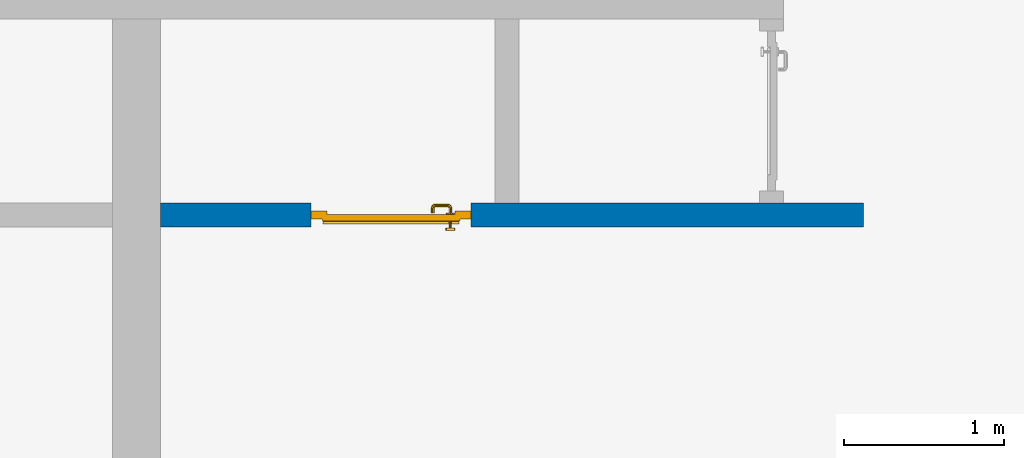
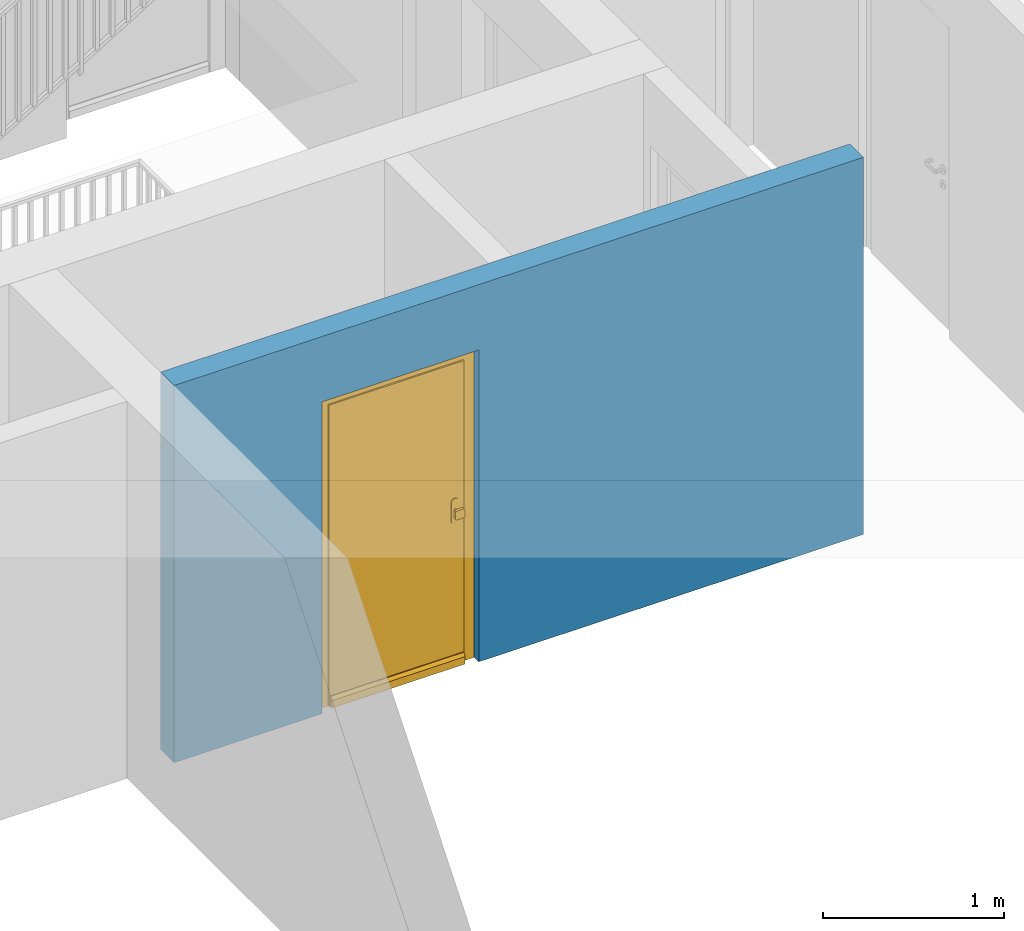
# One storey, part 3 of 54: 1 door, 1 wall, 1 opening.
"""IFC4 building model written with IfcOpenShell, lengths in metres."""

from ifc_helpers import new_model, entity, si_unit, converted_unit, derived_unit, direction, frame, origin_with_axes, place, context, subcontext, project, spatial, polygons, source, transform, mapped, material, type_object, element, fill, save


model = new_model("IFC4")

# Units and contexts
model_context = context("Model", 3, precision=1e-05, world=origin_with_axes(), true_north=direction((0.0, 1.0)))
body_context = subcontext(model_context, "Body", "Model", "MODEL_VIEW")
ifc_project = project(units=[si_unit("LENGTHUNIT", "METRE"), si_unit("AREAUNIT", "SQUARE_METRE"), si_unit("VOLUMEUNIT", "CUBIC_METRE"), converted_unit("PLANEANGLEUNIT", "DEGREE", entity("IfcPlaneAngleMeasure", 0.0174532925199), si_unit("PLANEANGLEUNIT", "RADIAN"), dimensions=[0, 0, 0, 0, 0, 0, 0]), converted_unit("TIMEUNIT", "Year", entity("IfcTimeMeasure", 31556926.0), si_unit("TIMEUNIT", "SECOND"), dimensions=[0, 0, 1, 0, 0, 0, 0]), si_unit("MASSUNIT", "GRAM", prefix="KILO"), si_unit("THERMODYNAMICTEMPERATUREUNIT", "DEGREE_CELSIUS"), si_unit("LUMINOUSINTENSITYUNIT", "LUMEN"), si_unit("ENERGYUNIT", "JOULE", prefix="MEGA"), derived_unit("THERMALCONDUCTANCEUNIT", [(si_unit("POWERUNIT", "WATT"), 1), (si_unit("LENGTHUNIT", "METRE"), -1), (si_unit("THERMODYNAMICTEMPERATUREUNIT", "KELVIN"), -1)]), derived_unit("SPECIFICHEATCAPACITYUNIT", [(si_unit("ENERGYUNIT", "JOULE"), 1), (si_unit("MASSUNIT", "GRAM", prefix="KILO"), -1), (si_unit("THERMODYNAMICTEMPERATUREUNIT", "KELVIN"), -1)]), derived_unit("MASSDENSITYUNIT", [(si_unit("MASSUNIT", "GRAM", prefix="KILO"), 1), (si_unit("VOLUMEUNIT", "CUBIC_METRE"), -1)])], contexts=[model_context])

# Site, building, storey
site_placement = place(None, origin_with_axes())
site = spatial("IfcSite", under=ifc_project, at=site_placement, CompositionType="ELEMENT")
building_placement = place(site_placement, origin_with_axes())
building = spatial("IfcBuilding", under=site, at=building_placement, CompositionType="ELEMENT")
storey_placement = place(building_placement, frame((0.0, 0.0, 6.29), z_axis=(0.0, 0.0, 1.0), x_axis=(1.0, 0.0, 0.0)))
storey = spatial("IfcBuildingStorey", under=building, at=storey_placement, Name="2. Geschoss", CompositionType="ELEMENT", Elevation=6.29)

# Wall, opening, door
ifc_material = material()
wall_type = type_object("IfcWallType", Name="150", PredefinedType="NOTDEFINED")
wall_placement = place(storey_placement, frame((-1.2021993804, -4.12881223104, 0.0), z_axis=(0.0, 0.0, 1.0), x_axis=(1.0, 0.0, 0.0)))
wall = element("IfcWall", 1, at=wall_placement, inside=storey, type_object=wall_type, material=ifc_material, Name="Wand-002", PredefinedType="NOTDEFINED", context=body_context, shape_type="Tessellation", body=[
    polygons([(1.09, 0.15, 2.1), (1.09, 0.15, 0.0), (0.15, 0.15, 0.0), (0.15, 0.15, 2.54), (4.54, 0.15, 2.54), (4.54, 0.15, 0.0), (2.09, 0.15, 0.0), (2.09, 0.15, 2.1), (1.09, 0.05, 0.0), (1.09, 0.0, 2.1), (1.09, 0.0, 0.0), (0.15, 0.0, 0.0), (0.15, 0.0, 2.54), (4.54, 0.0, 2.54), (4.54, 0.0, 0.0), (2.09, 0.05, 0.0), (2.09, 0.0, 0.0), (2.09, 0.0, 2.1)], [[[1, 2, 3, 4, 5, 6, 7, 8]], [[9, 2, 1, 10, 11]], [[2, 9, 11, 12, 3]], [[4, 3, 12, 13]], [[5, 4, 13, 14]], [[14, 15, 6, 5]], [[16, 7, 6, 15, 17]], [[8, 7, 16, 17, 18]], [[1, 8, 18, 10]], [[12, 11, 10, 18, 17, 15, 14, 13]]], closed=True),
])
opening_placement = place(wall_placement, frame((1.59, 0.0, 0.0), z_axis=(0.0, 0.0, 1.0), x_axis=(1.0, 0.0, 0.0)))
opening = element("IfcOpeningElement", 2, at=opening_placement, cuts=wall, context=body_context, identifier="Reference", shape_type="Tessellation", body=[
    polygons([(0.5, 0.05, 0.0), (0.5, 0.05, 2.1), (0.5, -0.001, 2.1), (0.5, -0.001, 0.0), (0.5, 0.151, 0.0), (0.5, 0.151, 2.1), (-0.5, 0.05, 2.1), (-0.5, -0.001, 2.1), (-0.5, 0.151, 2.1), (-0.5, -0.001, 0.0), (-0.5, 0.05, 0.0), (-0.5, 0.151, 0.0)], [[[1, 2, 3, 4]], [[2, 1, 5, 6]], [[7, 8, 3, 2, 6, 9]], [[8, 10, 4, 3]], [[1, 4, 10, 11, 12, 5]], [[6, 5, 12, 9]], [[7, 11, 10, 8]], [[11, 7, 9, 12]]], closed=True),
])
door_type = type_object("IfcDoorType", Name="Eingang 01 1-Fl 26", OperationType="SINGLE_SWING_RIGHT", PredefinedType="DOOR")
shared_shape = source(origin_with_axes(), body_context, "Body", "Tessellation", [
    polygons([(0.5, -0.05, 0.0), (0.5, -0.03, 0.0), (0.5, -0.03, 2.1), (0.5, -0.05, 2.1), (0.4, -0.05, 0.0), (0.4, -0.03, 0.0), (0.4, -0.03, 2.0), (0.1301, -0.03, 2.0), (0.0001, -0.03, 2.0), (-0.4, -0.03, 2.0), (-0.4, -0.03, 0.0), (-0.5, -0.03, 0.0), (-0.5, -0.03, 2.1), (-0.5, -0.05, 2.1), (-0.5, -0.05, 0.0), (-0.4, -0.05, 0.0), (-0.4, -0.05, 2.0), (0.0001, -0.05, 2.0), (0.1301, -0.05, 2.0), (0.4, -0.05, 2.0)], [[[1, 2, 3, 4]], [[5, 6, 2, 1]], [[2, 6, 7, 8, 9, 10, 11, 12, 13, 3]], [[4, 3, 13, 14]], [[1, 4, 14, 15, 16, 17, 18, 19, 20, 5]], [[20, 7, 6, 5]], [[19, 8, 7, 20]], [[18, 9, 8, 19]], [[17, 10, 9, 18]], [[16, 11, 10, 17]], [[15, 12, 11, 16]], [[14, 13, 12, 15]]], closed=True),
    polygons([(0.5, -0.03, 0.0), (0.5, 0.0, 0.0), (0.5, 0.0, 2.1), (0.5, -0.03, 2.1), (0.43, -0.03, 0.0), (0.43, 0.0, 0.0), (0.43, 0.0, 2.03), (0.1001, 0.0, 2.03), (0.0301, 0.0, 2.03), (-0.43, 0.0, 2.03), (-0.43, 0.0, 0.0), (-0.5, 0.0, 0.0), (-0.5, 0.0, 2.1), (-0.5, -0.03, 2.1), (-0.5, -0.03, 0.0), (-0.43, -0.03, 0.0), (-0.43, -0.03, 2.03), (0.0301, -0.03, 2.03), (0.1001, -0.03, 2.03), (0.43, -0.03, 2.03)], [[[1, 2, 3, 4]], [[5, 6, 2, 1]], [[2, 6, 7, 8, 9, 10, 11, 12, 13, 3]], [[4, 3, 13, 14]], [[1, 4, 14, 15, 16, 17, 18, 19, 20, 5]], [[20, 7, 6, 5]], [[19, 8, 7, 20]], [[18, 9, 8, 19]], [[17, 10, 9, 18]], [[16, 11, 10, 17]], [[15, 12, 11, 16]], [[14, 13, 12, 15]]], closed=True),
    polygons([(0.43, 0.01, 0.0), (-0.43, 0.01, 0.0), (-0.43, 0.01, 2.03), (0.43, 0.01, 2.03), (0.43, -0.03, 0.0), (-0.43, -0.03, 0.0), (-0.43, -0.03, 2.03), (0.43, -0.03, 2.03)], [[[1, 2, 3, 4]], [[2, 1, 5, 6]], [[3, 2, 6, 7]], [[4, 3, 7, 8]], [[1, 4, 8, 5]], [[6, 5, 8, 7]]], closed=True),
    polygons([(0.425, 0.03, 0.0), (-0.425, 0.03, 0.0), (-0.425, 0.03, 0.05), (0.425, 0.03, 0.05), (0.425, 0.01, 0.0), (-0.425, 0.01, 0.0), (-0.425, 0.01, 0.07), (-0.425, 0.015, 0.07), (0.425, 0.015, 0.07), (0.425, 0.01, 0.07)], [[[1, 2, 3, 4]], [[5, 6, 2, 1]], [[2, 6, 7, 8, 3]], [[4, 3, 8, 9]], [[1, 4, 9, 10, 5]], [[10, 7, 6, 5]], [[9, 8, 7, 10]]], closed=True),
    polygons([(-0.3835, -0.04, 1.0733826859), (-0.37, -0.04, 1.077), (-0.37, -0.0399, 1.077), (-0.3835, -0.0399, 1.0733826859), (-0.393382685902, -0.04, 1.0635), (-0.397, -0.04, 1.05), (-0.393382685902, -0.04, 1.0365), (-0.3835, -0.04, 1.0266173141), (-0.37, -0.04, 1.023), (-0.3565, -0.04, 1.0266173141), (-0.346617314098, -0.04, 1.0365), (-0.343, -0.04, 1.05), (-0.346617314098, -0.04, 1.0635), (-0.3565, -0.04, 1.0733826859), (-0.3565, -0.0399, 1.0733826859), (-0.37, -0.0301, 1.077), (-0.3835, -0.0301, 1.0733826859), (-0.393382685902, -0.0399, 1.0635), (-0.397, -0.0399, 1.05), (-0.393382685902, -0.0399, 1.0365), (-0.3835, -0.0399, 1.0266173141), (-0.37, -0.0399, 1.023), (-0.3565, -0.0399, 1.0266173141), (-0.346617314098, -0.0399, 1.0365), (-0.343, -0.0399, 1.05), (-0.346617314098, -0.0399, 1.0635), (-0.3565, -0.0301, 1.0733826859), (-0.37, -0.03, 1.077), (-0.3835, -0.03, 1.0733826859), (-0.393382685902, -0.0301, 1.0635), (-0.397, -0.0301, 1.05), (-0.393382685902, -0.0301, 1.0365), (-0.3835, -0.0301, 1.0266173141), (-0.37, -0.0301, 1.023), (-0.3565, -0.0301, 1.0266173141), (-0.346617314098, -0.0301, 1.0365), (-0.343, -0.0301, 1.05), (-0.346617314098, -0.0301, 1.0635), (-0.3565, -0.03, 1.0733826859), (-0.346617314098, -0.03, 1.0635), (-0.343, -0.03, 1.05), (-0.346617314098, -0.03, 1.0365), (-0.3565, -0.03, 1.0266173141), (-0.37, -0.03, 1.023), (-0.3835, -0.03, 1.0266173141), (-0.393382685902, -0.03, 1.0365), (-0.397, -0.03, 1.05), (-0.393382685902, -0.03, 1.0635)], [[[1, 2, 3, 4]], [[2, 1, 5, 6, 7, 8, 9, 10, 11, 12, 13, 14]], [[2, 14, 15, 3]], [[4, 3, 16, 17]], [[5, 1, 4, 18]], [[6, 5, 18, 19]], [[7, 6, 19, 20]], [[8, 7, 20, 21]], [[9, 8, 21, 22]], [[10, 9, 22, 23]], [[11, 10, 23, 24]], [[12, 11, 24, 25]], [[13, 12, 25, 26]], [[14, 13, 26, 15]], [[3, 15, 27, 16]], [[17, 16, 28, 29]], [[18, 4, 17, 30]], [[19, 18, 30, 31]], [[20, 19, 31, 32]], [[21, 20, 32, 33]], [[22, 21, 33, 34]], [[23, 22, 34, 35]], [[24, 23, 35, 36]], [[25, 24, 36, 37]], [[26, 25, 37, 38]], [[15, 26, 38, 27]], [[16, 27, 39, 28]], [[28, 39, 40, 41, 42, 43, 44, 45, 46, 47, 48, 29]], [[30, 17, 29, 48]], [[31, 30, 48, 47]], [[32, 31, 47, 46]], [[33, 32, 46, 45]], [[34, 33, 45, 44]], [[35, 34, 44, 43]], [[36, 35, 43, 42]], [[37, 36, 42, 41]], [[38, 37, 41, 40]], [[27, 38, 40, 39]]], closed=True),
    polygons([(-0.362532169224, -0.04, 0.959692280177), (-0.365, -0.04, 0.9544), (-0.365, -0.04, 0.952886751346), (-0.346703916638, -0.04, 0.96345), (-0.35655, -0.04, 0.973296083362), (-0.363279754556, -0.04, 0.961639806549), (-0.362532169224, -0.039, 0.959692280177), (-0.365, -0.039, 0.9544), (-0.365, -0.039, 0.952886751346), (-0.365, -0.039, 0.95), (-0.365, -0.039, 0.947113248654), (-0.365, -0.039, 0.941339745962), (-0.365, -0.039, 0.9375), (-0.365, -0.04, 0.9375), (-0.365, -0.04, 0.941339745962), (-0.365, -0.04, 0.947113248654), (-0.365, -0.04, 0.95), (-0.3431, -0.04, 0.95), (-0.346617314098, -0.04, 0.9635), (-0.3565, -0.04, 0.973382685902), (-0.364624817685, -0.04, 0.965143815798), (-0.37, -0.04, 0.9769), (-0.37, -0.04, 0.967425445323), (-0.364624817685, -0.039, 0.965143815798), (-0.363279754556, -0.039, 0.961639806549), (-0.35705, -0.039, 0.972430057958), (-0.347569942042, -0.039, 0.96295), (-0.3441, -0.039, 0.95), (-0.347569942042, -0.039, 0.93705), (-0.35705, -0.039, 0.927569942042), (-0.37, -0.039, 0.9241), (-0.37, -0.039, 0.9325), (-0.366464466094, -0.039, 0.933964466094), (-0.366464466094, -0.04, 0.933964466094), (-0.35655, -0.04, 0.926703916638), (-0.37, -0.04, 0.9325), (-0.37, -0.04, 0.9231), (-0.346703916638, -0.04, 0.93655), (-0.343, -0.04, 0.95), (-0.346617314098, -0.0399, 0.9635), (-0.3565, -0.0399, 0.973382685902), (-0.37, -0.04, 0.977), (-0.375375182315, -0.04, 0.965143815798), (-0.38345, -0.04, 0.973296083362), (-0.376720245444, -0.04, 0.961639806549), (-0.37, -0.039, 0.967425445323), (-0.37, -0.039, 0.9759), (-0.357, -0.039, 0.972516660498), (-0.347483339502, -0.039, 0.963), (-0.344, -0.039, 0.95), (-0.347483339502, -0.039, 0.937), (-0.357, -0.039, 0.927483339502), (-0.38295, -0.039, 0.927569942042), (-0.375, -0.039, 0.941339745962), (-0.375, -0.039, 0.9375), (-0.373535533906, -0.039, 0.933964466094), (-0.37, -0.039, 0.924), (-0.373535533906, -0.04, 0.933964466094), (-0.375, -0.04, 0.9375), (-0.375, -0.04, 0.941339745962), (-0.38345, -0.04, 0.926703916638), (-0.37, -0.04, 0.923), (-0.3565, -0.04, 0.926617314098), (-0.346617314098, -0.04, 0.9365), (-0.343, -0.0399, 0.95), (-0.346617314098, -0.0301, 0.9635), (-0.3565, -0.0301, 0.973382685902), (-0.37, -0.0399, 0.977), (-0.3835, -0.04, 0.973382685902), (-0.375375182315, -0.039, 0.965143815798), (-0.377467830776, -0.04, 0.959692280177), (-0.393296083362, -0.04, 0.96345), (-0.375, -0.04, 0.952886751346), (-0.375, -0.04, 0.9544), (-0.377467830776, -0.039, 0.959692280177), (-0.376720245444, -0.039, 0.961639806549), (-0.38295, -0.039, 0.972430057958), (-0.37, -0.039, 0.976), (-0.357, -0.0389, 0.972516660498), (-0.347483339502, -0.0389, 0.963), (-0.344, -0.0389, 0.95), (-0.347483339502, -0.0389, 0.937), (-0.357, -0.0389, 0.927483339502), (-0.392430057958, -0.039, 0.93705), (-0.375, -0.039, 0.947113248654), (-0.375, -0.039, 0.9544), (-0.375, -0.04, 0.95), (-0.375, -0.04, 0.947113248654), (-0.375, -0.039, 0.95), (-0.375, -0.039, 0.952886751346), (-0.383, -0.039, 0.927483339502), (-0.37, -0.0389, 0.924), (-0.393296083362, -0.04, 0.93655), (-0.3835, -0.04, 0.926617314098), (-0.37, -0.0399, 0.923), (-0.3565, -0.0399, 0.926617314098), (-0.346617314098, -0.0399, 0.9365), (-0.343, -0.0301, 0.95), (-0.346617314098, -0.03, 0.9635), (-0.3565, -0.03, 0.973382685902), (-0.37, -0.0301, 0.977), (-0.3835, -0.0399, 0.973382685902), (-0.393382685902, -0.04, 0.9635), (-0.3969, -0.04, 0.95), (-0.392430057958, -0.039, 0.96295), (-0.383, -0.039, 0.972516660498), (-0.37, -0.0389, 0.976), (-0.357, -0.0301, 0.972516660498), (-0.347483339502, -0.0301, 0.963), (-0.344, -0.0301, 0.95), (-0.347483339502, -0.0301, 0.937), (-0.357, -0.0301, 0.927483339502), (-0.392516660498, -0.039, 0.937), (-0.3959, -0.039, 0.95), (-0.383, -0.0389, 0.927483339502), (-0.37, -0.0301, 0.924), (-0.393382685902, -0.04, 0.9365), (-0.3835, -0.0399, 0.926617314098), (-0.37, -0.0301, 0.923), (-0.3565, -0.0301, 0.926617314098), (-0.346617314098, -0.0301, 0.9365), (-0.343, -0.03, 0.95), (-0.346703916638, -0.03, 0.96345), (-0.35655, -0.03, 0.973296083362), (-0.37, -0.03, 0.977), (-0.3835, -0.0301, 0.973382685902), (-0.393382685902, -0.0399, 0.9635), (-0.397, -0.04, 0.95), (-0.392516660498, -0.039, 0.963), (-0.383, -0.0389, 0.972516660498), (-0.37, -0.0301, 0.976), (-0.357, -0.03, 0.972516660498), (-0.347483339502, -0.03, 0.963), (-0.344, -0.03, 0.95), (-0.347483339502, -0.03, 0.937), (-0.357, -0.03, 0.927483339502), (-0.392516660498, -0.0389, 0.937), (-0.396, -0.039, 0.95), (-0.383, -0.0301, 0.927483339502), (-0.37, -0.03, 0.924), (-0.393382685902, -0.0399, 0.9365), (-0.3835, -0.0301, 0.926617314098), (-0.37, -0.03, 0.923), (-0.3565, -0.03, 0.926617314098), (-0.346617314098, -0.03, 0.9365), (-0.3431, -0.03, 0.95), (-0.347396736961, -0.03, 0.96305), (-0.35695, -0.03, 0.972603263039), (-0.37, -0.03, 0.9769), (-0.3835, -0.03, 0.973382685902), (-0.393382685902, -0.0301, 0.9635), (-0.397, -0.0399, 0.95), (-0.392516660498, -0.0389, 0.963), (-0.383, -0.0301, 0.972516660498), (-0.37, -0.03, 0.976), (-0.3439, -0.03, 0.95), (-0.347396736961, -0.03, 0.93695), (-0.35695, -0.03, 0.927396736961), (-0.392516660498, -0.0301, 0.937), (-0.396, -0.0389, 0.95), (-0.383, -0.03, 0.927483339502), (-0.37, -0.03, 0.9239), (-0.393382685902, -0.0301, 0.9365), (-0.3835, -0.03, 0.926617314098), (-0.37, -0.03, 0.9231), (-0.35655, -0.03, 0.926703916638), (-0.346703916638, -0.03, 0.93655), (-0.37, -0.03, 0.9761), (-0.38345, -0.03, 0.973296083362), (-0.393382685902, -0.03, 0.9635), (-0.397, -0.0301, 0.95), (-0.392516660498, -0.0301, 0.963), (-0.383, -0.03, 0.972516660498), (-0.392516660498, -0.03, 0.937), (-0.396, -0.0301, 0.95), (-0.38305, -0.03, 0.927396736961), (-0.393382685902, -0.03, 0.9365), (-0.38345, -0.03, 0.926703916638), (-0.38305, -0.03, 0.972603263039), (-0.393296083362, -0.03, 0.96345), (-0.397, -0.03, 0.95), (-0.392516660498, -0.03, 0.963), (-0.392603263039, -0.03, 0.93695), (-0.396, -0.03, 0.95), (-0.393296083362, -0.03, 0.93655), (-0.392603263039, -0.03, 0.96305), (-0.3969, -0.03, 0.95), (-0.3961, -0.03, 0.95)], [[[1, 2, 3, 4, 5, 6]], [[2, 1, 7, 8]], [[2, 8, 9, 10, 11, 12, 13, 14, 15, 16, 17, 3]], [[17, 18, 4, 3]], [[19, 20, 5, 4]], [[21, 6, 5, 22, 23]], [[1, 6, 21, 24, 25, 7]], [[7, 25, 26, 27, 9, 8]], [[9, 27, 28, 10]], [[10, 28, 29, 11]], [[11, 29, 30, 12]], [[31, 32, 33, 13, 12, 30]], [[14, 13, 33, 34]], [[35, 15, 14, 34, 36, 37]], [[15, 35, 38, 16]], [[16, 38, 18, 17]], [[39, 19, 4, 18]], [[40, 41, 20, 19]], [[20, 42, 22, 5]], [[43, 23, 22, 44, 45]], [[21, 23, 46, 24]], [[24, 46, 47, 26, 25]], [[27, 26, 48, 49]], [[28, 27, 49, 50]], [[29, 28, 50, 51]], [[30, 29, 51, 52]], [[53, 54, 55, 56, 32, 31]], [[34, 33, 32, 36]], [[31, 30, 52, 57]], [[37, 36, 58, 59, 60, 61]], [[62, 63, 35, 37]], [[63, 64, 38, 35]], [[64, 39, 18, 38]], [[65, 40, 19, 39]], [[66, 67, 41, 40]], [[41, 68, 42, 20]], [[42, 69, 44, 22]], [[23, 43, 70, 46]], [[71, 45, 44, 72, 73, 74]], [[43, 45, 71, 75, 76, 70]], [[70, 76, 77, 47, 46]], [[26, 47, 78, 48]], [[49, 48, 79, 80]], [[50, 49, 80, 81]], [[51, 50, 81, 82]], [[52, 51, 82, 83]], [[54, 53, 84, 85]], [[86, 74, 73, 87, 88, 60, 59, 55, 54, 85, 89, 90]], [[58, 56, 55, 59]], [[36, 32, 56, 58]], [[53, 31, 57, 91]], [[57, 52, 83, 92]], [[88, 93, 61, 60]], [[94, 62, 37, 61]], [[95, 96, 63, 62]], [[96, 97, 64, 63]], [[97, 65, 39, 64]], [[98, 66, 40, 65]], [[99, 100, 67, 66]], [[67, 101, 68, 41]], [[68, 102, 69, 42]], [[69, 103, 72, 44]], [[73, 72, 104, 87]], [[71, 74, 86, 75]], [[75, 86, 90, 105, 77, 76]], [[47, 77, 106, 78]], [[48, 78, 107, 79]], [[80, 79, 108, 109]], [[81, 80, 109, 110]], [[82, 81, 110, 111]], [[83, 82, 111, 112]], [[84, 53, 91, 113]], [[85, 84, 114, 89]], [[87, 104, 93, 88]], [[89, 114, 105, 90]], [[91, 57, 92, 115]], [[92, 83, 112, 116]], [[117, 94, 61, 93]], [[118, 95, 62, 94]], [[119, 120, 96, 95]], [[120, 121, 97, 96]], [[121, 98, 65, 97]], [[122, 99, 66, 98]], [[123, 124, 100, 99]], [[100, 125, 101, 67]], [[101, 126, 102, 68]], [[102, 127, 103, 69]], [[103, 128, 104, 72]], [[77, 105, 129, 106]], [[78, 106, 130, 107]], [[79, 107, 131, 108]], [[109, 108, 132, 133]], [[110, 109, 133, 134]], [[111, 110, 134, 135]], [[112, 111, 135, 136]], [[113, 91, 115, 137]], [[114, 84, 113, 138]], [[128, 117, 93, 104]], [[105, 114, 138, 129]], [[115, 92, 116, 139]], [[116, 112, 136, 140]], [[141, 118, 94, 117]], [[142, 119, 95, 118]], [[143, 144, 120, 119]], [[144, 145, 121, 120]], [[145, 122, 98, 121]], [[146, 123, 99, 122]], [[147, 148, 124, 123]], [[124, 149, 125, 100]], [[125, 150, 126, 101]], [[126, 151, 127, 102]], [[127, 152, 128, 103]], [[106, 129, 153, 130]], [[107, 130, 154, 131]], [[108, 131, 155, 132]], [[133, 132, 148, 147]], [[134, 133, 147, 156]], [[135, 134, 156, 157]], [[136, 135, 157, 158]], [[137, 115, 139, 159]], [[138, 113, 137, 160]], [[152, 141, 117, 128]], [[129, 138, 160, 153]], [[139, 116, 140, 161]], [[140, 136, 158, 162]], [[163, 142, 118, 141]], [[164, 143, 119, 142]], [[165, 166, 144, 143]], [[166, 167, 145, 144]], [[167, 146, 122, 145]], [[156, 147, 123, 146]], [[148, 168, 149, 124]], [[149, 169, 150, 125]], [[150, 170, 151, 126]], [[151, 171, 152, 127]], [[130, 153, 172, 154]], [[131, 154, 173, 155]], [[132, 155, 168, 148]], [[157, 156, 146, 167]], [[158, 157, 167, 166]], [[159, 139, 161, 174]], [[160, 137, 159, 175]], [[171, 163, 141, 152]], [[153, 160, 175, 172]], [[161, 140, 162, 176]], [[162, 158, 166, 165]], [[177, 164, 142, 163]], [[178, 165, 143, 164]], [[168, 179, 169, 149]], [[169, 180, 170, 150]], [[170, 181, 171, 151]], [[154, 172, 182, 173]], [[155, 173, 179, 168]], [[174, 161, 176, 183]], [[175, 159, 174, 184]], [[181, 177, 163, 171]], [[172, 175, 184, 182]], [[176, 162, 165, 178]], [[185, 178, 164, 177]], [[179, 186, 180, 169]], [[180, 187, 181, 170]], [[173, 182, 186, 179]], [[183, 176, 178, 185]], [[184, 174, 183, 188]], [[187, 185, 177, 181]], [[182, 184, 188, 186]], [[186, 188, 187, 180]], [[188, 183, 185, 187]]], closed=True),
    polygons([(-0.38, -0.04, 1.05), (-0.377071067812, -0.04, 1.04292893219), (-0.377071067812, -0.070696439392, 1.04292893219), (-0.38, -0.0709849140336, 1.05), (-0.37, -0.04, 1.04), (-0.37, -0.07, 1.04), (-0.375518993221, -0.0784992452783, 1.04292893219), (-0.378277987014, -0.0796420579258, 1.05), (-0.377071067812, -0.04, 1.05707106781), (-0.377071067812, -0.070696439392, 1.05707106781), (-0.362928932188, -0.04, 1.04292893219), (-0.362928932188, -0.069303560608, 1.04292893219), (-0.368858192988, -0.0757402514855, 1.04), (-0.370704557509, -0.0857045575088, 1.04292893219), (-0.372816199938, -0.0878161999379, 1.05), (-0.375518993221, -0.0784992452783, 1.05707106781), (-0.37, -0.04, 1.06), (-0.37, -0.07, 1.06), (-0.36, -0.04, 1.05), (-0.36, -0.0690150859664, 1.05), (-0.362197392755, -0.0729812576926, 1.04292893219), (-0.365606601718, -0.0806066017178, 1.04), (-0.363499245278, -0.0905189932208, 1.04292893219), (-0.364642057926, -0.0932779870137, 1.05), (-0.370704557509, -0.0857045575088, 1.05707106781), (-0.368858192988, -0.0757402514855, 1.06), (-0.362928932188, -0.04, 1.05707106781), (-0.362928932188, -0.069303560608, 1.05707106781), (-0.359438398962, -0.0718384450452, 1.05), (-0.360508645927, -0.0755086459268, 1.04292893219), (-0.360740251485, -0.0838581929877, 1.04), (-0.355696439392, -0.0920710678119, 1.04292893219), (-0.355984914034, -0.095, 1.05), (-0.363499245278, -0.0905189932208, 1.05707106781), (-0.365606601718, -0.0806066017178, 1.06), (-0.362197392755, -0.0729812576926, 1.05707106781), (-0.358397003498, -0.0733970034977, 1.05), (-0.357981257693, -0.0771973927545, 1.04292893219), (-0.355, -0.085, 1.04), (-0.274303560608, -0.0920710678119, 1.04292893219), (-0.274015085966, -0.095, 1.05), (-0.355696439392, -0.0920710678119, 1.05707106781), (-0.360740251485, -0.0838581929877, 1.06), (-0.360508645927, -0.0755086459268, 1.05707106781), (-0.356838445045, -0.0744383989617, 1.05), (-0.354303560608, -0.0779289321881, 1.04292893219), (-0.275, -0.085, 1.04), (-0.266500754722, -0.0905189932208, 1.04292893219), (-0.265357942074, -0.0932779870137, 1.05), (-0.274303560608, -0.0920710678119, 1.05707106781), (-0.355, -0.085, 1.06), (-0.357981257693, -0.0771973927545, 1.05707106781), (-0.354015085966, -0.075, 1.05), (-0.275696439392, -0.0779289321881, 1.04292893219), (-0.269259748515, -0.0838581929877, 1.04), (-0.259295442491, -0.0857045575088, 1.04292893219), (-0.257183800062, -0.0878161999379, 1.05), (-0.266500754722, -0.0905189932208, 1.05707106781), (-0.275, -0.085, 1.06), (-0.354303560608, -0.0779289321881, 1.05707106781), (-0.275984914034, -0.075, 1.05), (-0.272018742307, -0.0771973927545, 1.04292893219), (-0.264393398282, -0.0806066017178, 1.04), (-0.254481006779, -0.0784992452783, 1.04292893219), (-0.251722012986, -0.0796420579258, 1.05), (-0.259295442491, -0.0857045575088, 1.05707106781), (-0.269259748515, -0.0838581929877, 1.06), (-0.275696439392, -0.0779289321881, 1.05707106781), (-0.273161554955, -0.0744383989617, 1.05), (-0.269491354073, -0.0755086459268, 1.04292893219), (-0.261141807012, -0.0757402514855, 1.04), (-0.252928932188, -0.070696439392, 1.04292893219), (-0.25, -0.0709849140336, 1.05), (-0.254481006779, -0.0784992452783, 1.05707106781), (-0.264393398282, -0.0806066017178, 1.06), (-0.272018742307, -0.0771973927545, 1.05707106781), (-0.271602996502, -0.0733970034977, 1.05), (-0.267802607245, -0.0729812576926, 1.04292893219), (-0.26, -0.07, 1.04), (-0.252928932188, -0.04, 1.04292893219), (-0.25, -0.04, 1.05), (-0.252928932188, -0.070696439392, 1.05707106781), (-0.261141807012, -0.0757402514855, 1.06), (-0.269491354073, -0.0755086459268, 1.05707106781), (-0.270561601038, -0.0718384450452, 1.05), (-0.267071067812, -0.069303560608, 1.04292893219), (-0.26, -0.04, 1.04), (-0.267071067812, -0.04, 1.04292893219), (-0.27, -0.04, 1.05), (-0.267071067812, -0.04, 1.05707106781), (-0.26, -0.04, 1.06), (-0.252928932188, -0.04, 1.05707106781), (-0.26, -0.07, 1.06), (-0.267802607245, -0.0729812576926, 1.05707106781), (-0.27, -0.0690150859664, 1.05), (-0.267071067812, -0.069303560608, 1.05707106781)], [[[1, 2, 3, 4]], [[2, 5, 6, 3]], [[4, 3, 7, 8]], [[9, 1, 4, 10]], [[5, 11, 12, 6]], [[3, 6, 13, 7]], [[8, 7, 14, 15]], [[10, 4, 8, 16]], [[17, 9, 10, 18]], [[11, 19, 20, 12]], [[6, 12, 21, 13]], [[7, 13, 22, 14]], [[15, 14, 23, 24]], [[16, 8, 15, 25]], [[18, 10, 16, 26]], [[27, 17, 18, 28]], [[19, 27, 28, 20]], [[12, 20, 29, 21]], [[13, 21, 30, 22]], [[14, 22, 31, 23]], [[24, 23, 32, 33]], [[25, 15, 24, 34]], [[26, 16, 25, 35]], [[28, 18, 26, 36]], [[20, 28, 36, 29]], [[21, 29, 37, 30]], [[22, 30, 38, 31]], [[23, 31, 39, 32]], [[33, 32, 40, 41]], [[34, 24, 33, 42]], [[35, 25, 34, 43]], [[36, 26, 35, 44]], [[29, 36, 44, 37]], [[30, 37, 45, 38]], [[31, 38, 46, 39]], [[32, 39, 47, 40]], [[41, 40, 48, 49]], [[42, 33, 41, 50]], [[43, 34, 42, 51]], [[44, 35, 43, 52]], [[37, 44, 52, 45]], [[38, 45, 53, 46]], [[39, 46, 54, 47]], [[40, 47, 55, 48]], [[49, 48, 56, 57]], [[50, 41, 49, 58]], [[51, 42, 50, 59]], [[52, 43, 51, 60]], [[45, 52, 60, 53]], [[46, 53, 61, 54]], [[47, 54, 62, 55]], [[48, 55, 63, 56]], [[57, 56, 64, 65]], [[58, 49, 57, 66]], [[59, 50, 58, 67]], [[60, 51, 59, 68]], [[53, 60, 68, 61]], [[54, 61, 69, 62]], [[55, 62, 70, 63]], [[56, 63, 71, 64]], [[65, 64, 72, 73]], [[66, 57, 65, 74]], [[67, 58, 66, 75]], [[68, 59, 67, 76]], [[61, 68, 76, 69]], [[62, 69, 77, 70]], [[63, 70, 78, 71]], [[64, 71, 79, 72]], [[73, 72, 80, 81]], [[74, 65, 73, 82]], [[75, 66, 74, 83]], [[76, 67, 75, 84]], [[69, 76, 84, 77]], [[70, 77, 85, 78]], [[71, 78, 86, 79]], [[72, 79, 87, 80]], [[81, 80, 87, 88, 89, 90, 91, 92]], [[82, 73, 81, 92]], [[83, 74, 82, 93]], [[84, 75, 83, 94]], [[77, 84, 94, 85]], [[78, 85, 95, 86]], [[79, 86, 88, 87]], [[86, 95, 89, 88]], [[95, 96, 90, 89]], [[96, 93, 91, 90]], [[93, 82, 92, 91]], [[94, 83, 93, 96]], [[85, 94, 96, 95]]], closed=False),
    polygons([(-0.364696699141, 0.015, 1.04469669914), (-0.3625, 0.015, 1.05), (-0.364696699141, 0.015, 1.05530330086), (-0.37, 0.015, 1.0575), (-0.375303300859, 0.015, 1.05530330086), (-0.3775, 0.015, 1.05), (-0.375303300859, 0.015, 1.04469669914), (-0.37, 0.015, 1.0425), (-0.364696699141, 0.055, 1.04469669914), (-0.3625, 0.055, 1.05), (-0.364696699141, 0.055, 1.05530330086), (-0.37, 0.055, 1.0575), (-0.375303300859, 0.055, 1.05530330086), (-0.3775, 0.055, 1.05), (-0.375303300859, 0.055, 1.04469669914), (-0.37, 0.055, 1.0425)], [[[1, 2, 3, 4, 5, 6, 7, 8]], [[1, 9, 10, 2]], [[2, 10, 11, 3]], [[3, 11, 12, 4]], [[4, 12, 13, 5]], [[5, 13, 14, 6]], [[6, 14, 15, 7]], [[7, 15, 16, 8]], [[8, 16, 9, 1]], [[9, 16, 15, 14, 13, 12, 11, 10]]], closed=True),
    polygons([(-0.395, 0.01, 0.975), (-0.395, 0.015, 0.975), (-0.393096988313, 0.015, 0.965432914191), (-0.393096988313, 0.01, 0.965432914191), (-0.395, 0.01, 1.1), (-0.395, 0.015, 1.1), (-0.393096988313, 0.015, 1.10956708581), (-0.38767766953, 0.015, 1.11767766953), (-0.379567085809, 0.015, 1.12309698831), (-0.37, 0.015, 1.125), (-0.360432914191, 0.015, 1.12309698831), (-0.35232233047, 0.015, 1.11767766953), (-0.346903011687, 0.015, 1.10956708581), (-0.345, 0.015, 1.1), (-0.345, 0.015, 0.975), (-0.346903011687, 0.015, 0.965432914191), (-0.35232233047, 0.015, 0.95732233047), (-0.360432914191, 0.015, 0.951903011687), (-0.37, 0.015, 0.95), (-0.379567085809, 0.015, 0.951903011687), (-0.38767766953, 0.015, 0.95732233047), (-0.38767766953, 0.01, 0.95732233047), (-0.379567085809, 0.01, 0.951903011687), (-0.37, 0.01, 0.95), (-0.360432914191, 0.01, 0.951903011687), (-0.35232233047, 0.01, 0.95732233047), (-0.346903011687, 0.01, 0.965432914191), (-0.345, 0.01, 0.975), (-0.345, 0.01, 1.1), (-0.346903011687, 0.01, 1.10956708581), (-0.35232233047, 0.01, 1.11767766953), (-0.360432914191, 0.01, 1.12309698831), (-0.37, 0.01, 1.125), (-0.379567085809, 0.01, 1.12309698831), (-0.38767766953, 0.01, 1.11767766953), (-0.393096988313, 0.01, 1.10956708581)], [[[1, 2, 3, 4]], [[5, 6, 2, 1]], [[2, 6, 7, 8, 9, 10, 11, 12, 13, 14, 15, 16, 17, 18, 19, 20, 21, 3]], [[4, 3, 21, 22]], [[1, 4, 22, 23, 24, 25, 26, 27, 28, 29, 30, 31, 32, 33, 34, 35, 36, 5]], [[36, 7, 6, 5]], [[35, 8, 7, 36]], [[34, 9, 8, 35]], [[33, 10, 9, 34]], [[32, 11, 10, 33]], [[31, 12, 11, 32]], [[30, 13, 12, 31]], [[29, 14, 13, 30]], [[28, 15, 14, 29]], [[27, 16, 15, 28]], [[26, 17, 16, 27]], [[25, 18, 17, 26]], [[24, 19, 18, 25]], [[23, 20, 19, 24]], [[22, 21, 20, 23]]], closed=True),
    polygons([(-0.39, 0.055, 1.08), (-0.39, 0.07, 1.08), (-0.395, 0.07, 1.07866025404), (-0.395, 0.055, 1.07866025404), (-0.35, 0.055, 1.08), (-0.35, 0.07, 1.08), (-0.345, 0.07, 1.07866025404), (-0.341339745962, 0.07, 1.075), (-0.34, 0.07, 1.07), (-0.34, 0.07, 1.03), (-0.341339745962, 0.07, 1.025), (-0.345, 0.07, 1.02133974596), (-0.35, 0.07, 1.02), (-0.39, 0.07, 1.02), (-0.395, 0.07, 1.02133974596), (-0.398660254038, 0.07, 1.025), (-0.4, 0.07, 1.03), (-0.4, 0.07, 1.07), (-0.398660254038, 0.07, 1.075), (-0.398660254038, 0.055, 1.075), (-0.4, 0.055, 1.07), (-0.4, 0.055, 1.03), (-0.398660254038, 0.055, 1.025), (-0.395, 0.055, 1.02133974596), (-0.39, 0.055, 1.02), (-0.35, 0.055, 1.02), (-0.345, 0.055, 1.02133974596), (-0.341339745962, 0.055, 1.025), (-0.34, 0.055, 1.03), (-0.34, 0.055, 1.07), (-0.341339745962, 0.055, 1.075), (-0.345, 0.055, 1.07866025404)], [[[1, 2, 3, 4]], [[5, 6, 2, 1]], [[2, 6, 7, 8, 9, 10, 11, 12, 13, 14, 15, 16, 17, 18, 19, 3]], [[4, 3, 19, 20]], [[1, 4, 20, 21, 22, 23, 24, 25, 26, 27, 28, 29, 30, 31, 32, 5]], [[32, 7, 6, 5]], [[31, 8, 7, 32]], [[30, 9, 8, 31]], [[29, 10, 9, 30]], [[28, 11, 10, 29]], [[27, 12, 11, 28]], [[26, 13, 12, 27]], [[25, 14, 13, 26]], [[24, 15, 14, 25]], [[23, 16, 15, 24]], [[22, 17, 16, 23]], [[21, 18, 17, 22]], [[20, 19, 18, 21]]], closed=True),
])
door_placement = place(opening_placement, frame((0.4, 0.0, 0.0), z_axis=(0.0, 0.0, 1.0), x_axis=(-1.0, 0.0, 0.0)))
door = element("IfcDoor", 3, at=door_placement, inside=storey, type_object=door_type, OverallHeight=2.1, OverallWidth=1.0, PredefinedType="DOOR", context=body_context, shape_type="MappedRepresentation", body=[
    mapped(shared_shape, transform((0.4, -0.05, 0.0))),
])
fill(opening, door)

save(model, "model.ifc")
